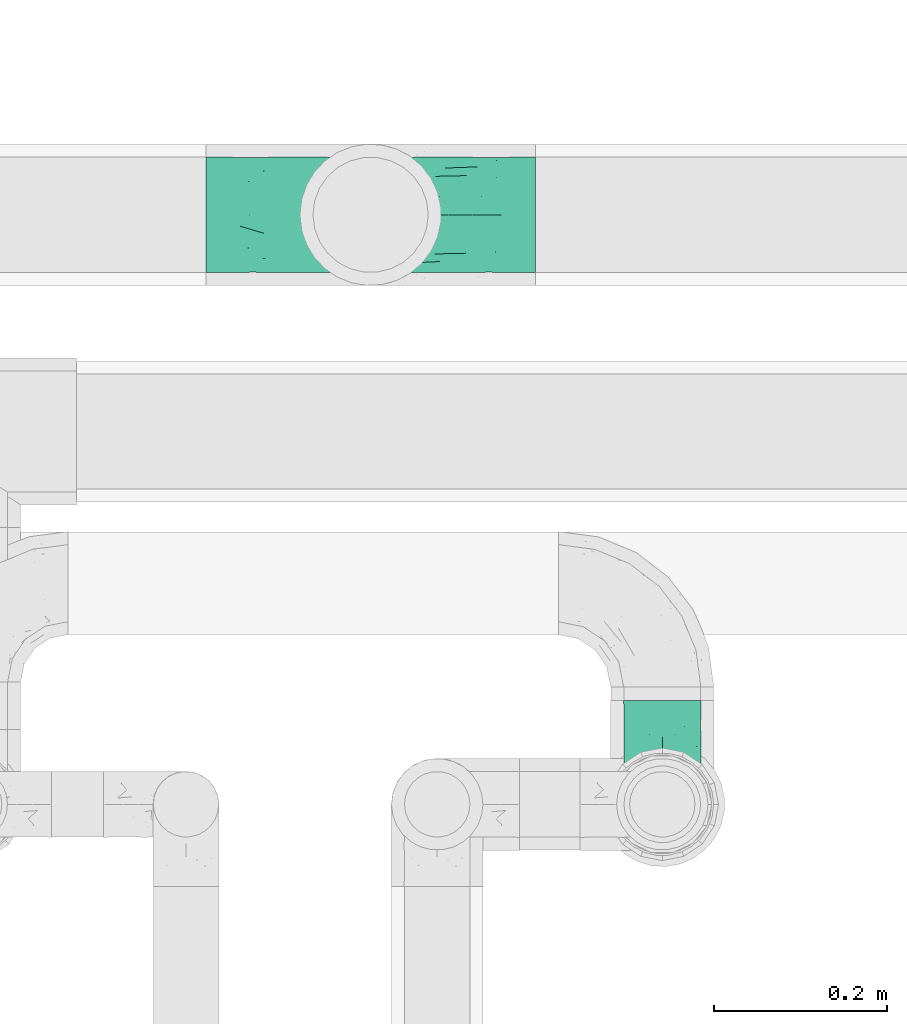
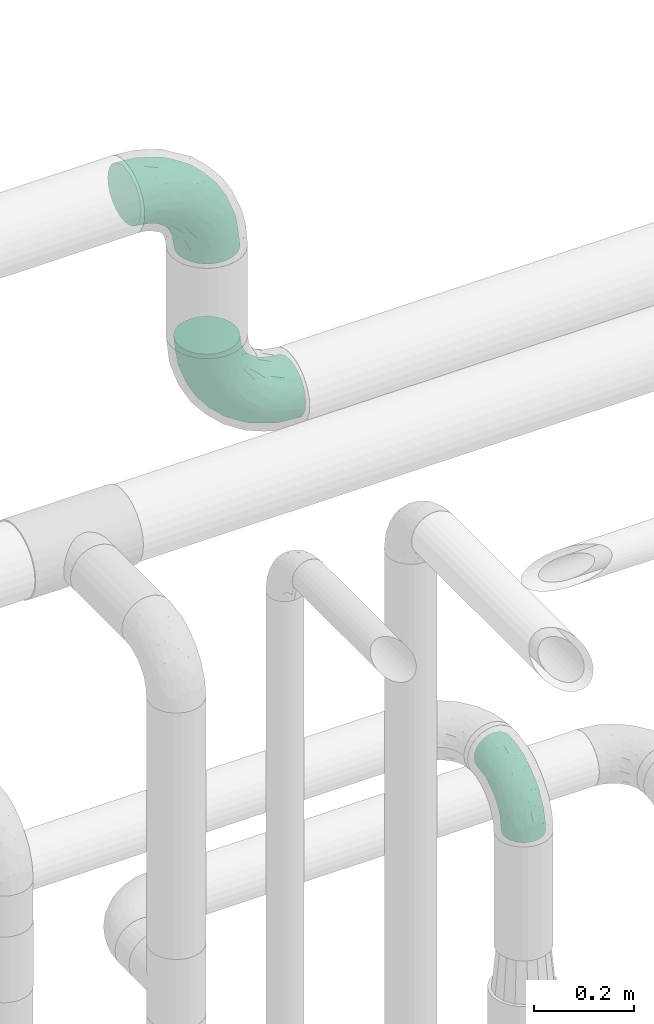
# One storey, part 708 of 824: 3 flow fittings.
"""IFC2X3 building model written with IfcOpenShell, lengths in millimetres."""

from ifc_helpers import new_model, entity, si_unit, converted_unit, derived_unit, direction, frame, origin, place, context, subcontext, project, spatial, faceted_brep, source, transform, mapped, material, type_object, type_shapes, element, save


model = new_model("IFC2X3")

# Units and contexts
model_context = context("Model", 3, precision=0.01, world=origin(), true_north=direction((6.12303176911189e-17, 1.0)))
body_context = subcontext(model_context, "Body", "Model", "MODEL_VIEW")
ifc_project = project(units=[si_unit("LENGTHUNIT", "METRE", prefix="MILLI"), si_unit("AREAUNIT", "SQUARE_METRE"), si_unit("VOLUMEUNIT", "CUBIC_METRE"), converted_unit("PLANEANGLEUNIT", "DEGREE", entity("IfcRatioMeasure", 0.0174532925199433), si_unit("PLANEANGLEUNIT", "RADIAN"), dimensions=[0, 0, 0, 0, 0, 0, 0]), si_unit("MASSUNIT", "GRAM", prefix="KILO"), derived_unit("MASSDENSITYUNIT", [(si_unit("MASSUNIT", "GRAM", prefix="KILO"), 1), (si_unit("LENGTHUNIT", "METRE"), -3)]), derived_unit("MOMENTOFINERTIAUNIT", [(si_unit("LENGTHUNIT", "METRE"), 4)]), si_unit("TIMEUNIT", "SECOND"), si_unit("FREQUENCYUNIT", "HERTZ"), si_unit("THERMODYNAMICTEMPERATUREUNIT", "DEGREE_CELSIUS"), derived_unit("THERMALTRANSMITTANCEUNIT", [(si_unit("MASSUNIT", "GRAM", prefix="KILO"), 1), (si_unit("THERMODYNAMICTEMPERATUREUNIT", "KELVIN"), -1), (si_unit("TIMEUNIT", "SECOND"), -3)]), derived_unit("VOLUMETRICFLOWRATEUNIT", [(si_unit("LENGTHUNIT", "METRE"), 3), (si_unit("TIMEUNIT", "SECOND"), -1)]), derived_unit("MASSFLOWRATEUNIT", [(si_unit("MASSUNIT", "GRAM", prefix="KILO"), 1), (si_unit("TIMEUNIT", "SECOND"), -1)]), derived_unit("ROTATIONALFREQUENCYUNIT", [(si_unit("TIMEUNIT", "SECOND"), -1)]), si_unit("ELECTRICCURRENTUNIT", "AMPERE"), si_unit("ELECTRICVOLTAGEUNIT", "VOLT"), si_unit("POWERUNIT", "WATT"), si_unit("FORCEUNIT", "NEWTON", prefix="KILO"), si_unit("ILLUMINANCEUNIT", "LUX"), si_unit("LUMINOUSFLUXUNIT", "LUMEN"), si_unit("LUMINOUSINTENSITYUNIT", "CANDELA"), derived_unit("USERDEFINED", [(si_unit("MASSUNIT", "GRAM", prefix="KILO"), -1), (si_unit("LENGTHUNIT", "METRE"), -2), (si_unit("TIMEUNIT", "SECOND"), 3), (si_unit("LUMINOUSFLUXUNIT", "LUMEN"), 1)]), derived_unit("LINEARVELOCITYUNIT", [(si_unit("LENGTHUNIT", "METRE"), 1), (si_unit("TIMEUNIT", "SECOND"), -1)]), si_unit("PRESSUREUNIT", "PASCAL"), derived_unit("USERDEFINED", [(si_unit("LENGTHUNIT", "METRE"), -2), (si_unit("MASSUNIT", "GRAM", prefix="KILO"), 1), (si_unit("TIMEUNIT", "SECOND"), -2)]), derived_unit("LINEARFORCEUNIT", [(si_unit("MASSUNIT", "GRAM", prefix="KILO"), 1), (si_unit("LENGTHUNIT", "METRE"), 1), (si_unit("TIMEUNIT", "SECOND"), -2), (si_unit("LENGTHUNIT", "METRE"), -1)]), derived_unit("PLANARFORCEUNIT", [(si_unit("MASSUNIT", "GRAM", prefix="KILO"), 1), (si_unit("LENGTHUNIT", "METRE"), 1), (si_unit("TIMEUNIT", "SECOND"), -2), (si_unit("LENGTHUNIT", "METRE"), -2)])], contexts=[model_context])

# Site, building, storey
site_placement = place(None, origin())
site = spatial("IfcSite", under=ifc_project, at=site_placement, CompositionType="ELEMENT")
building_placement = place(site_placement, origin())
building = spatial("IfcBuilding", under=site, at=building_placement, CompositionType="ELEMENT")
storey_placement = place(building_placement, frame((0.0, 0.0, 28200.0)))
storey = spatial("IfcBuildingStorey", under=building, at=storey_placement, CompositionType="ELEMENT", Elevation=28200.0)

# Flow fittings
ifc_material = material()
pipe_fitting_type_1 = type_object("IfcPipeFittingType", PredefinedType="NOTDEFINED", material=ifc_material)
shared_shape_1 = source(origin(), body_context, "Body", "Brep", [
    faceted_brep([(-190.0, 33.25, -57.59), (-190.0, 17.21, -64.23), (-190.0, 0.0, -66.5), (-190.0, -17.21, -64.23), (-190.0, -33.25, -57.59), (-190.0, -47.02, -47.02), (-190.0, -57.59, -33.25), (-190.0, -64.23, -17.21), (-190.0, -66.5, 0.0), (-190.0, -64.23, 17.21), (-190.0, -57.59, 33.25), (-190.0, -47.02, 47.02), (-190.0, -33.25, 57.59), (-190.0, -17.21, 64.23), (-190.0, 0.0, 66.5), (-190.0, 17.21, 64.23), (-190.0, 33.25, 57.59), (-190.0, 47.02, 47.02), (-190.0, 57.59, 33.25), (-190.0, 64.23, 17.21), (-190.0, 66.5, 0.0), (-190.0, 64.23, -17.21), (-190.0, 57.59, -33.25), (-190.0, 47.02, -47.02), (0.0, 190.0, -66.5), (-17.21, 190.0, -64.23), (-33.25, 190.0, -57.59), (-47.02, 190.0, -47.02), (-57.59, 190.0, -33.25), (-64.23, 190.0, -17.21), (-66.5, 190.0, 0.0), (-64.23, 190.0, 17.21), (-57.59, 190.0, 33.25), (-47.02, 190.0, 47.02), (-33.25, 190.0, 57.59), (-17.21, 190.0, 64.23), (0.0, 190.0, 66.5), (17.21, 190.0, 64.23), (33.25, 190.0, 57.59), (47.02, 190.0, 47.02), (57.59, 190.0, 33.25), (64.23, 190.0, 17.21), (66.5, 190.0, 0.0), (64.23, 190.0, -17.21), (57.59, 190.0, -33.25), (47.02, 190.0, -47.02), (33.25, 190.0, -57.59), (17.21, 190.0, -64.23), (-28.55, 147.02, 62.42), (-13.57, 135.63, 66.28), (-140.38, -49.33, 38.23), (-80.14, -30.55, 35.23), (-124.14, -33.9, 50.4), (-141.11, -22.46, 60.31), (-81.84, -6.19, 57.13), (-101.3, 6.38, 65.03), (-125.04, -54.28, 21.95), (-139.96, -61.57, 0.0), (-30.59, -6.47, 21.28), (-47.5, -23.27, 0.0), (-8.63, 8.63, 0.0), (-101.64, 52.37, 61.01), (-147.02, 28.55, 62.42), (-107.01, 35.47, 64.88), (-72.79, -35.94, 16.05), (-91.84, -46.98, 0.0), (-42.05, -7.73, 34.33), (-4.24, 27.9, 35.0), (-46.26, 0.22, 45.96), (-148.38, -6.74, 65.57), (-135.63, 13.57, 66.28), (-58.81, 143.49, 42.9), (-64.43, 158.86, 27.32), (33.87, 124.03, 50.39), (-24.86, 95.88, 66.5), (-6.38, 101.3, 65.03), (-68.44, 29.45, 65.52), (-33.12, 50.38, 63.42), (-47.55, 58.11, 66.37), (-68.78, 157.93, 15.75), (-78.73, 128.81, 21.25), (-145.19, 58.3, 42.81), (-126.57, 73.12, 34.22), (-158.86, 64.43, 27.32), (-157.93, 68.78, 15.75), (-73.06, 126.96, 34.0), (-99.23, 99.23, 24.99), (-94.51, 94.51, 37.44), (-160.28, 41.89, 53.91), (-151.84, 72.54, 0.0), (-128.81, 78.73, 21.25), (-117.41, 90.09, 0.0), (7.42, 29.34, 16.05), (36.05, 72.53, 15.16), (23.27, 47.5, 0.0), (30.73, 80.34, 35.12), (61.57, 139.96, 0.0), (62.07, 150.38, 13.25), (46.98, 91.84, 0.0), (22.46, 141.08, 60.31), (6.16, 81.82, 57.15), (-39.4, 100.2, 64.86), (54.07, 123.33, 21.27), (49.32, 140.35, 38.22), (-83.36, -19.52, 48.87), (6.74, 148.38, 65.57), (-85.07, 81.39, 53.88), (-123.92, 51.92, 55.31), (-90.09, 117.41, 0.0), (-72.54, 151.84, 0.0), (-101.92, 101.92, 11.85), (-42.36, 157.28, 54.02), (-54.08, 118.94, 55.5), (-1.97, 47.81, 48.28), (22.27, 83.36, 46.49), (-79.1, 73.18, 59.88), (-73.69, 63.3, 64.01), (-96.26, 24.55, 66.5), (-73.56, 111.53, 44.32), (-111.08, 72.88, 45.21), (-31.39, 31.39, 56.96), (-71.89, 12.15, 62.21), (-42.48, 117.92, 61.28), (-157.28, 42.36, -54.02), (-72.79, -35.94, -16.05), (-44.48, -10.39, -33.14), (-30.59, -6.47, -21.28), (-101.3, 6.38, -65.03), (-148.38, -6.74, -65.57), (-135.63, 13.57, -66.28), (-157.93, 68.78, -15.75), (-128.81, 78.73, -21.25), (-158.86, 64.43, -27.32), (-147.02, 28.55, -62.42), (-100.2, 39.4, -64.86), (-95.88, 24.86, -66.5), (-150.3, -62.06, -13.27), (-101.92, 101.92, -11.85), (-143.49, 58.81, -42.9), (6.74, 148.38, -65.57), (-13.57, 135.63, -66.28), (-52.37, 101.64, -61.01), (-81.39, 85.07, -53.88), (-51.92, 123.92, -55.31), (-124.14, -33.9, -50.4), (-81.84, -6.19, -57.13), (-78.6, -18.73, -47.44), (-140.38, -49.33, -38.23), (-24.55, 96.26, -66.5), (-35.47, 107.01, -64.88), (-28.55, 147.02, -62.42), (-80.14, -30.55, -35.23), (-123.37, -54.04, -21.36), (-64.43, 158.86, -27.32), (-68.78, 157.93, -15.75), (-73.18, 79.1, -59.88), (-63.3, 73.69, -64.01), (-29.45, 68.44, -65.52), (-50.38, 33.12, -63.42), (-58.11, 47.55, -66.37), (-78.73, 128.81, -21.25), (-99.23, 99.23, -24.99), (-126.96, 73.06, -34.0), (-94.51, 94.51, -37.44), (-58.3, 145.19, -42.81), (-73.12, 126.57, -34.22), (-118.94, 54.08, -55.5), (-41.89, 160.28, -53.91), (22.46, 141.08, -60.31), (6.16, 81.82, -57.15), (-6.38, 101.3, -65.03), (33.87, 124.03, -50.39), (54.35, 125.32, -21.97), (35.86, 72.99, -16.69), (49.34, 140.46, -38.23), (7.54, 29.16, -15.21), (-141.11, -22.46, -60.31), (30.73, 80.34, -35.12), (22.8, 84.14, -46.35), (-4.38, 23.43, -29.89), (5.33, 47.62, -41.81), (-111.53, 73.56, -44.32), (-72.88, 111.08, -45.21), (-48.51, 2.91, -49.35), (-20.15, 28.66, -49.63), (-27.46, 10.86, -41.59), (-12.16, 71.91, -62.22), (2.48, 58.84, -50.8), (-117.92, 42.48, -61.28), (-31.39, 31.39, -56.96)], [[[0, 1, 2, 3, 4, 5, 6, 7, 8, 9, 10, 11, 12, 13, 14, 15, 16, 17, 18, 19, 20, 21, 22, 23]], [[24, 25, 26, 27, 28, 29, 30, 31, 32, 33, 34, 35, 36, 37, 38, 39, 40, 41, 42, 43, 44, 45, 46, 47]], [[35, 48, 49]], [[50, 51, 52]], [[53, 54, 55]], [[56, 10, 9]], [[9, 8, 57]], [[58, 59, 60]], [[56, 50, 10]], [[61, 62, 63]], [[64, 65, 59]], [[58, 64, 59]], [[12, 11, 52]], [[66, 67, 68]], [[52, 53, 12]], [[69, 70, 14]], [[71, 32, 72]], [[73, 39, 38]], [[49, 74, 75]], [[62, 16, 15]], [[14, 70, 15]], [[72, 32, 31]], [[13, 69, 14]], [[76, 77, 78]], [[79, 80, 72]], [[81, 82, 83]], [[62, 15, 70]], [[20, 19, 84]], [[85, 86, 87]], [[81, 17, 88]], [[89, 90, 91]], [[19, 83, 84]], [[16, 88, 17]], [[85, 71, 72]], [[58, 60, 92]], [[49, 36, 35]], [[93, 92, 94]], [[35, 34, 48]], [[92, 93, 95]], [[96, 97, 98]], [[73, 99, 100]], [[49, 101, 74]], [[102, 97, 40]], [[39, 73, 103]], [[95, 102, 103]], [[40, 39, 103]], [[12, 53, 13]], [[68, 54, 104]], [[42, 97, 96]], [[41, 97, 42]], [[99, 38, 37]], [[37, 36, 105]], [[61, 106, 107]], [[108, 80, 109]], [[10, 50, 11]], [[108, 91, 110]], [[109, 79, 30]], [[64, 51, 56]], [[71, 33, 32]], [[86, 110, 90]], [[92, 60, 94]], [[111, 34, 33]], [[71, 112, 111]], [[49, 48, 101]], [[9, 57, 56]], [[17, 81, 18]], [[65, 56, 57]], [[113, 114, 100]], [[75, 105, 49]], [[115, 61, 116]], [[58, 92, 67]], [[99, 73, 38]], [[70, 117, 63]], [[18, 83, 19]], [[71, 85, 118]], [[119, 107, 106]], [[83, 82, 90]], [[51, 50, 56]], [[52, 11, 50]], [[51, 64, 58]], [[56, 65, 64]], [[94, 98, 93]], [[67, 92, 95]], [[95, 114, 113]], [[68, 120, 54]], [[54, 53, 52]], [[69, 53, 55]], [[104, 51, 68]], [[121, 76, 55]], [[103, 73, 114]], [[102, 40, 103]], [[105, 99, 37]], [[75, 77, 100]], [[75, 100, 99]], [[100, 120, 113]], [[111, 48, 34]], [[115, 101, 122]], [[122, 101, 48]], [[101, 116, 78]], [[116, 63, 117]], [[78, 117, 76]], [[63, 62, 70]], [[88, 62, 107]], [[98, 102, 93]], [[95, 93, 102]], [[66, 68, 51]], [[113, 68, 67]], [[49, 105, 36]], [[99, 105, 75]], [[53, 69, 13]], [[70, 69, 55]], [[70, 55, 117]], [[61, 63, 116]], [[76, 117, 55]], [[116, 117, 78]], [[121, 55, 54]], [[76, 121, 77]], [[100, 77, 120]], [[75, 78, 77]], [[54, 120, 121]], [[77, 121, 120]], [[71, 111, 33]], [[111, 112, 122]], [[68, 113, 120]], [[95, 113, 67]], [[61, 115, 106]], [[62, 61, 107]], [[118, 112, 71]], [[119, 87, 82]], [[101, 115, 116]], [[112, 106, 115]], [[79, 72, 31]], [[72, 80, 85]], [[86, 85, 80]], [[118, 85, 87]], [[119, 118, 87]], [[112, 118, 106]], [[30, 79, 31]], [[109, 80, 79]], [[81, 83, 18]], [[84, 83, 90]], [[119, 82, 81]], [[86, 82, 87]], [[107, 119, 81]], [[118, 119, 106]], [[90, 89, 84]], [[20, 84, 89]], [[62, 88, 16]], [[81, 88, 107]], [[101, 78, 74]], [[78, 75, 74]], [[80, 108, 110]], [[82, 86, 90]], [[90, 110, 91]], [[80, 110, 86]], [[40, 97, 41]], [[98, 97, 102]], [[111, 122, 48]], [[115, 122, 112]], [[54, 52, 104]], [[51, 104, 52]], [[51, 58, 66]], [[67, 66, 58]], [[103, 114, 95]], [[100, 114, 73]], [[23, 123, 0]], [[124, 125, 126]], [[127, 128, 129]], [[130, 131, 132]], [[133, 134, 129]], [[129, 135, 127]], [[89, 130, 20]], [[8, 136, 57]], [[91, 131, 89]], [[59, 65, 124]], [[108, 137, 91]], [[132, 22, 21]], [[138, 23, 22]], [[139, 140, 24]], [[141, 142, 143]], [[144, 145, 146]], [[5, 144, 147]], [[140, 148, 149]], [[8, 7, 136]], [[138, 22, 132]], [[6, 5, 147]], [[141, 150, 149]], [[147, 151, 152]], [[152, 136, 6]], [[29, 153, 154]], [[125, 124, 151]], [[136, 65, 57]], [[155, 141, 156]], [[128, 3, 2]], [[126, 59, 124]], [[129, 134, 135]], [[157, 158, 159]], [[160, 161, 137]], [[1, 0, 133]], [[129, 2, 1]], [[162, 138, 132]], [[161, 163, 162]], [[154, 30, 29]], [[144, 5, 4]], [[153, 164, 165]], [[150, 26, 25]], [[166, 123, 138]], [[24, 47, 139]], [[24, 140, 25]], [[28, 153, 29]], [[26, 167, 27]], [[168, 169, 170]], [[140, 150, 25]], [[27, 164, 28]], [[46, 171, 168]], [[172, 98, 173]], [[59, 126, 60]], [[27, 167, 164]], [[44, 174, 45]], [[173, 98, 94]], [[175, 173, 94]], [[176, 144, 4]], [[171, 46, 45]], [[44, 43, 172]], [[43, 96, 172]], [[42, 96, 43]], [[144, 146, 151]], [[144, 176, 145]], [[177, 178, 174]], [[173, 175, 179]], [[44, 172, 174]], [[98, 172, 96]], [[1, 133, 129]], [[179, 180, 177]], [[109, 160, 108]], [[46, 168, 47]], [[176, 4, 3]], [[138, 162, 181]], [[182, 143, 142]], [[153, 165, 160]], [[94, 60, 175]], [[177, 172, 173]], [[151, 147, 144]], [[152, 6, 147]], [[128, 176, 3]], [[127, 158, 145]], [[127, 145, 176]], [[183, 184, 185]], [[65, 152, 124]], [[151, 124, 152]], [[177, 174, 172]], [[171, 45, 174]], [[169, 168, 171]], [[139, 168, 170]], [[178, 177, 180]], [[186, 157, 170]], [[187, 169, 178]], [[126, 179, 175]], [[123, 133, 0]], [[155, 134, 188]], [[188, 134, 133]], [[134, 156, 159]], [[156, 149, 148]], [[159, 148, 157]], [[149, 150, 140]], [[167, 150, 143]], [[60, 126, 175]], [[125, 179, 126]], [[129, 128, 2]], [[176, 128, 127]], [[168, 139, 47]], [[140, 139, 170]], [[140, 170, 148]], [[141, 149, 156]], [[157, 148, 170]], [[156, 148, 159]], [[186, 170, 169]], [[157, 186, 158]], [[145, 158, 189]], [[127, 159, 158]], [[169, 189, 186]], [[158, 186, 189]], [[180, 179, 185]], [[173, 179, 177]], [[187, 184, 189]], [[178, 171, 174]], [[187, 178, 180]], [[169, 171, 178]], [[184, 180, 185]], [[189, 169, 187]], [[138, 123, 23]], [[123, 166, 188]], [[141, 155, 142]], [[150, 141, 143]], [[181, 166, 138]], [[182, 163, 165]], [[134, 155, 156]], [[166, 142, 155]], [[130, 132, 21]], [[132, 131, 162]], [[161, 162, 131]], [[181, 162, 163]], [[182, 181, 163]], [[166, 181, 142]], [[20, 130, 21]], [[89, 131, 130]], [[164, 153, 28]], [[154, 153, 160]], [[182, 165, 164]], [[161, 165, 163]], [[143, 182, 164]], [[181, 182, 142]], [[160, 109, 154]], [[30, 154, 109]], [[150, 167, 26]], [[164, 167, 143]], [[134, 159, 135]], [[159, 127, 135]], [[131, 91, 137]], [[165, 161, 160]], [[160, 137, 108]], [[131, 137, 161]], [[6, 136, 7]], [[65, 136, 152]], [[183, 189, 184]], [[146, 183, 125]], [[146, 125, 151]], [[179, 125, 185]], [[123, 188, 133]], [[155, 188, 166]], [[180, 184, 187]], [[185, 125, 183]], [[146, 145, 183]], [[189, 183, 145]]]),
])
type_shapes(pipe_fitting_type_1, [shared_shape_1])
for number, where, z_axis, x_axis in (
    (1, (57911.05, 18180.1, 2900.0), (0.0, 1.0, 0.0), (-1.0, 0.0, 0.0)),
    (2, (57911.05, 18180.1, 3499.74), (0.0, -1.0, 0.0), (0.0, 0.0, 1.0)),
):
    element("IfcFlowFitting", number, at=place(storey_placement, frame(where, z_axis=z_axis, x_axis=x_axis)), inside=storey, type_object=pipe_fitting_type_1, material=ifc_material, context=body_context, shape_type="MappedRepresentation", body=[
        mapped(shared_shape_1, transform((0.0, 0.0, 0.0), scale=1.0)),
    ])
pipe_fitting_type_2 = type_object("IfcPipeFittingType", PredefinedType="NOTDEFINED", material=ifc_material)
shared_shape_2 = source(origin(), body_context, "Body", "Brep", [
    faceted_brep([(-120.0, 22.25, -38.54), (-120.0, 11.52, -42.98), (-120.0, 0.0, -44.5), (-120.0, -11.52, -42.98), (-120.0, -22.25, -38.54), (-120.0, -31.47, -31.47), (-120.0, -38.54, -22.25), (-120.0, -42.98, -11.52), (-120.0, -44.5, 0.0), (-120.0, -42.98, 11.52), (-120.0, -38.54, 22.25), (-120.0, -31.47, 31.47), (-120.0, -22.25, 38.54), (-120.0, -11.52, 42.98), (-120.0, 0.0, 44.5), (-120.0, 11.52, 42.98), (-120.0, 22.25, 38.54), (-120.0, 31.47, 31.47), (-120.0, 38.54, 22.25), (-120.0, 42.98, 11.52), (-120.0, 44.5, 0.0), (-120.0, 42.98, -11.52), (-120.0, 38.54, -22.25), (-120.0, 31.47, -31.47), (0.0, 120.0, -44.5), (-11.52, 120.0, -42.98), (-22.25, 120.0, -38.54), (-31.47, 120.0, -31.47), (-38.54, 120.0, -22.25), (-42.98, 120.0, -11.52), (-44.5, 120.0, 0.0), (-42.98, 120.0, 11.52), (-38.54, 120.0, 22.25), (-31.47, 120.0, 31.47), (-22.25, 120.0, 38.54), (-11.52, 120.0, 42.98), (0.0, 120.0, 44.5), (11.52, 120.0, 42.98), (22.25, 120.0, 38.54), (31.47, 120.0, 31.47), (38.54, 120.0, 22.25), (42.98, 120.0, 11.52), (44.5, 120.0, 0.0), (42.98, 120.0, -11.52), (38.54, 120.0, -22.25), (31.47, 120.0, -31.47), (22.25, 120.0, -38.54), (11.52, 120.0, -42.98), (-20.51, 85.66, 41.98), (-29.31, 93.55, 36.45), (-98.0, -41.6, 0.0), (-80.92, -37.22, 14.68), (-66.68, -9.63, 39.67), (-84.59, -24.55, 33.9), (-50.35, -12.87, 32.85), (-77.42, -38.89, 0.0), (-22.01, -9.62, 13.21), (-37.75, -22.46, 0.0), (-20.72, -9.39, 0.0), (-89.18, -33.47, 25.4), (12.87, 50.35, 32.85), (24.55, 84.59, 33.9), (9.63, 66.68, 39.67), (-49.55, -27.06, 11.21), (-28.67, -9.99, 21.67), (-52.01, -22.41, 23.47), (-95.53, -16.28, 40.49), (-86.01, -3.42, 43.77), (22.41, 52.01, 23.47), (9.05, 21.37, 13.44), (26.5, 49.37, 12.73), (33.47, 89.18, 25.4), (37.22, 80.92, 14.68), (16.28, 95.53, 40.49), (3.42, 86.01, 43.77), (-7.84, 52.6, 43.16), (-84.39, 31.88, 36.84), (-30.52, 34.28, 44.33), (-21.99, 28.55, 42.22), (-93.56, 38.23, 28.63), (-65.04, 31.74, 41.51), (-91.98, 19.0, 41.83), (-34.03, 70.24, 39.41), (-96.36, 44.0, 18.64), (-98.49, 46.74, 8.65), (-76.5, 56.97, 9.76), (-4.96, 4.47, 11.32), (-7.16, 6.18, 18.93), (-56.62, 75.93, 12.18), (-66.61, 66.61, 0.0), (-92.12, 7.25, 44.33), (-7.23, 92.66, 44.32), (30.68, 57.59, 0.0), (-44.45, 94.8, 18.75), (-36.39, 101.98, 28.14), (-46.83, 97.45, 9.69), (-38.03, 47.61, 43.21), (-24.7, 65.7, 43.29), (41.6, 98.0, 0.0), (-54.11, 72.8, 21.53), (-47.95, 9.75, 42.93), (-18.65, 18.65, 37.89), (-91.11, 50.25, 0.0), (-50.25, 91.11, 0.0), (-57.59, -30.68, 0.0), (-44.16, 67.2, 34.92), (-55.15, 62.16, 29.74), (-68.1, 47.21, 32.31), (-51.09, 51.09, 38.36), (-16.69, 62.62, 44.46), (-58.26, 18.84, 44.48), (-71.55, 55.71, 20.49), (-43.13, 80.04, 29.45), (-37.23, 0.88, 36.78), (-18.15, 10.22, 33.09), (5.51, 28.08, 26.74), (-3.68, 3.68, 0.0), (9.39, 20.72, 0.0), (-2.58, 27.98, 33.59), (-2.38, 41.22, 38.93), (-16.09, 4.55, 27.06), (38.89, 77.42, 0.0), (22.46, 37.75, 0.0), (-92.66, 7.23, -44.32), (-22.01, -9.62, -13.21), (-49.81, -26.66, -12.91), (-28.67, -9.99, -21.67), (-62.62, 16.69, -44.46), (-65.04, 31.74, -41.51), (-38.89, 47.26, -43.11), (-56.62, 75.93, -12.18), (-93.56, 38.23, -28.63), (-84.39, 31.88, -36.84), (16.28, 95.53, -40.49), (3.42, 86.01, -43.77), (-98.49, 46.74, -8.65), (-44.45, 94.8, -18.75), (-54.11, 72.8, -21.53), (-76.5, 56.97, -9.76), (24.55, 84.59, -33.9), (9.63, 66.68, -39.67), (-96.36, 44.0, -18.64), (-29.4, 93.16, -36.47), (-91.98, 19.0, -41.83), (-80.92, -37.22, -14.68), (-52.6, 7.84, -43.16), (-86.01, -3.42, -43.77), (-89.18, -33.47, -25.4), (-52.01, -22.41, -23.47), (-50.35, -12.87, -32.85), (-84.59, -24.55, -33.9), (-66.68, -9.63, -39.67), (-95.53, -16.28, -40.49), (-68.1, 47.21, -32.31), (-35.81, 11.1, -40.85), (-19.61, 28.53, -41.59), (-18.65, 18.65, -37.89), (-4.97, 4.47, -11.34), (9.05, 21.37, -13.44), (-34.28, 30.52, -44.33), (-9.75, 47.95, -42.93), (-2.58, 27.98, -33.59), (-18.15, 10.22, -33.09), (-46.83, 97.45, -9.69), (12.87, 50.35, -32.85), (26.8, 49.13, -11.4), (-7.34, 92.03, -44.33), (-21.02, 83.86, -42.03), (-44.6, 66.82, -34.8), (-55.46, 62.18, -29.47), (37.22, 80.92, -14.68), (33.47, 89.18, -25.4), (-34.39, 70.11, -39.28), (-25.04, 64.41, -43.37), (-18.84, 58.26, -44.48), (22.41, 52.01, -23.47), (-36.39, 101.98, -28.14), (-51.09, 51.09, -38.36), (-43.13, 80.04, -29.45), (-71.55, 55.71, -20.49), (-7.15, 6.2, -18.94), (5.51, 28.08, -26.74), (-37.23, 0.88, -36.78), (-2.38, 41.22, -38.93), (-16.09, 4.55, -27.06)], [[[0, 1, 2, 3, 4, 5, 6, 7, 8, 9, 10, 11, 12, 13, 14, 15, 16, 17, 18, 19, 20, 21, 22, 23]], [[24, 25, 26, 27, 28, 29, 30, 31, 32, 33, 34, 35, 36, 37, 38, 39, 40, 41, 42, 43, 44, 45, 46, 47]], [[48, 34, 49]], [[50, 51, 9]], [[52, 53, 54]], [[9, 51, 10]], [[55, 51, 50]], [[56, 57, 58]], [[51, 59, 10]], [[60, 61, 62]], [[63, 64, 65]], [[13, 12, 66]], [[67, 14, 13]], [[68, 69, 70]], [[71, 68, 72]], [[38, 73, 61]], [[74, 75, 62]], [[17, 16, 76]], [[77, 78, 75]], [[79, 18, 17]], [[80, 76, 81]], [[35, 34, 48]], [[49, 82, 48]], [[18, 83, 19]], [[16, 81, 76]], [[20, 19, 84]], [[85, 84, 83]], [[56, 86, 87]], [[85, 88, 89]], [[37, 36, 74]], [[90, 14, 67]], [[79, 17, 76]], [[63, 65, 51]], [[13, 66, 67]], [[61, 39, 38]], [[91, 74, 36]], [[70, 92, 72]], [[93, 94, 32]], [[95, 88, 93]], [[62, 73, 74]], [[82, 96, 97]], [[40, 72, 41]], [[72, 68, 70]], [[71, 72, 40]], [[34, 33, 49]], [[72, 98, 41]], [[99, 93, 88]], [[71, 39, 61]], [[78, 100, 101]], [[85, 89, 102]], [[53, 52, 66]], [[103, 95, 30]], [[12, 11, 53]], [[103, 89, 88]], [[104, 57, 63]], [[91, 48, 97]], [[93, 32, 31]], [[33, 32, 94]], [[16, 15, 81]], [[105, 106, 107]], [[76, 107, 79]], [[35, 91, 36]], [[80, 96, 108]], [[31, 95, 93]], [[65, 53, 59]], [[73, 38, 37]], [[75, 74, 109]], [[61, 60, 68]], [[11, 10, 59]], [[54, 53, 65]], [[100, 67, 52]], [[110, 81, 90]], [[15, 14, 90]], [[76, 80, 108]], [[107, 76, 108]], [[83, 79, 111]], [[94, 49, 33]], [[82, 105, 108]], [[84, 85, 102]], [[111, 88, 85]], [[99, 88, 111]], [[94, 93, 112]], [[48, 91, 35]], [[74, 91, 109]], [[69, 87, 86]], [[113, 54, 114]], [[64, 56, 87]], [[60, 115, 68]], [[116, 117, 86]], [[69, 68, 115]], [[79, 83, 18]], [[85, 83, 111]], [[81, 110, 80]], [[110, 77, 96]], [[110, 96, 80]], [[97, 96, 109]], [[107, 108, 105]], [[111, 79, 107]], [[77, 75, 109]], [[118, 119, 101]], [[96, 77, 109]], [[77, 110, 100]], [[67, 100, 110]], [[100, 52, 113]], [[60, 119, 118]], [[118, 120, 115]], [[64, 54, 65]], [[114, 120, 118]], [[118, 115, 60]], [[115, 120, 87]], [[74, 73, 37]], [[61, 73, 62]], [[53, 66, 12]], [[67, 66, 52]], [[110, 90, 67]], [[15, 90, 81]], [[105, 49, 112]], [[96, 82, 108]], [[119, 60, 62]], [[118, 101, 114]], [[62, 75, 119]], [[78, 119, 75]], [[49, 105, 82]], [[105, 112, 106]], [[99, 112, 93]], [[111, 107, 106]], [[113, 114, 101]], [[54, 120, 114]], [[100, 113, 101]], [[52, 54, 113]], [[20, 84, 102]], [[83, 84, 19]], [[111, 106, 99]], [[112, 99, 106]], [[100, 78, 77]], [[119, 78, 101]], [[39, 71, 40]], [[68, 71, 61]], [[65, 59, 51]], [[11, 59, 53]], [[30, 95, 31]], [[103, 88, 95]], [[9, 8, 50]], [[98, 72, 121]], [[98, 42, 41]], [[49, 94, 112]], [[56, 63, 57]], [[51, 55, 104]], [[92, 121, 72]], [[86, 58, 116]], [[54, 64, 120]], [[115, 87, 69]], [[120, 64, 87]], [[58, 86, 56]], [[86, 117, 69]], [[91, 97, 109]], [[122, 69, 117]], [[82, 97, 48]], [[63, 56, 64]], [[104, 63, 51]], [[69, 122, 70]], [[92, 70, 122]], [[123, 2, 1]], [[124, 125, 126]], [[127, 128, 129]], [[103, 130, 89]], [[23, 131, 132]], [[47, 133, 134]], [[102, 135, 20]], [[130, 136, 137]], [[102, 138, 135]], [[139, 140, 133]], [[22, 21, 141]], [[27, 26, 142]], [[46, 45, 139]], [[0, 143, 1]], [[6, 144, 7]], [[145, 146, 127]], [[144, 50, 7]], [[147, 148, 144]], [[144, 6, 147]], [[149, 150, 151]], [[4, 3, 152]], [[23, 22, 131]], [[132, 131, 153]], [[43, 42, 98]], [[125, 104, 144]], [[154, 155, 156]], [[146, 151, 152]], [[4, 150, 5]], [[123, 146, 2]], [[157, 158, 117]], [[130, 138, 89]], [[29, 28, 136]], [[159, 160, 155]], [[161, 162, 156]], [[89, 138, 102]], [[163, 30, 29]], [[164, 140, 139]], [[163, 136, 130]], [[23, 132, 0]], [[158, 165, 122]], [[25, 24, 166]], [[0, 132, 143]], [[4, 152, 150]], [[142, 26, 167]], [[3, 2, 146]], [[167, 26, 25]], [[133, 47, 46]], [[168, 153, 169]], [[146, 145, 151]], [[149, 126, 148]], [[44, 170, 171]], [[24, 47, 134]], [[170, 44, 43]], [[144, 148, 125]], [[170, 98, 121]], [[168, 142, 172]], [[129, 173, 174]], [[98, 170, 43]], [[147, 5, 150]], [[157, 58, 124]], [[92, 122, 165]], [[134, 166, 24]], [[175, 139, 171]], [[28, 27, 176]], [[29, 136, 163]], [[132, 128, 143]], [[45, 44, 171]], [[164, 139, 175]], [[160, 134, 140]], [[174, 173, 166]], [[141, 131, 22]], [[132, 153, 177]], [[128, 132, 177]], [[123, 143, 127]], [[172, 142, 167]], [[176, 142, 178]], [[130, 179, 138]], [[138, 179, 141]], [[176, 136, 28]], [[130, 137, 179]], [[174, 166, 134]], [[167, 25, 166]], [[143, 123, 1]], [[146, 123, 127]], [[150, 149, 148]], [[157, 124, 180]], [[181, 161, 164]], [[181, 158, 180]], [[124, 126, 180]], [[170, 165, 175]], [[141, 21, 135]], [[131, 141, 179]], [[131, 179, 153]], [[179, 137, 169]], [[129, 128, 177]], [[127, 143, 128]], [[129, 177, 172]], [[129, 174, 159]], [[159, 145, 127]], [[182, 154, 156]], [[129, 159, 127]], [[159, 174, 160]], [[134, 160, 174]], [[140, 164, 183]], [[162, 182, 156]], [[126, 149, 184]], [[181, 164, 175]], [[164, 161, 183]], [[158, 181, 175]], [[184, 162, 161]], [[146, 152, 3]], [[150, 152, 151]], [[139, 133, 46]], [[134, 133, 140]], [[184, 161, 181]], [[161, 156, 183]], [[155, 183, 156]], [[160, 140, 183]], [[184, 149, 162]], [[182, 162, 149]], [[149, 151, 182]], [[154, 151, 145]], [[151, 154, 182]], [[159, 154, 145]], [[159, 155, 154]], [[183, 155, 160]], [[141, 135, 138]], [[20, 135, 21]], [[136, 178, 137]], [[169, 178, 168]], [[172, 167, 173]], [[168, 172, 177]], [[153, 168, 177]], [[142, 168, 178]], [[179, 169, 153]], [[137, 178, 169]], [[5, 147, 6]], [[148, 147, 150]], [[175, 171, 170]], [[45, 171, 139]], [[130, 103, 163]], [[30, 163, 103]], [[50, 144, 55]], [[50, 8, 7]], [[142, 176, 27]], [[136, 176, 178]], [[126, 125, 148]], [[104, 55, 144]], [[170, 121, 92]], [[58, 57, 124]], [[180, 126, 184]], [[181, 180, 184]], [[180, 158, 157]], [[158, 122, 117]], [[58, 157, 116]], [[172, 173, 129]], [[116, 157, 117]], [[166, 173, 167]], [[124, 57, 125]], [[104, 125, 57]], [[175, 165, 158]], [[92, 165, 170]]]),
])
type_shapes(pipe_fitting_type_2, [shared_shape_2])
flow_fitting_placement = place(storey_placement, frame((58247.57, 17500.0, 2300.0), z_axis=(1.0, 0.0, 0.0), x_axis=(0.0, -1.0, 0.0)))
element("IfcFlowFitting", 3, at=flow_fitting_placement, inside=storey, type_object=pipe_fitting_type_2, material=ifc_material, context=body_context, shape_type="MappedRepresentation", body=[
    mapped(shared_shape_2, transform((0.0, 0.0, 0.0), scale=1.0)),
])

save(model, "model.ifc")
